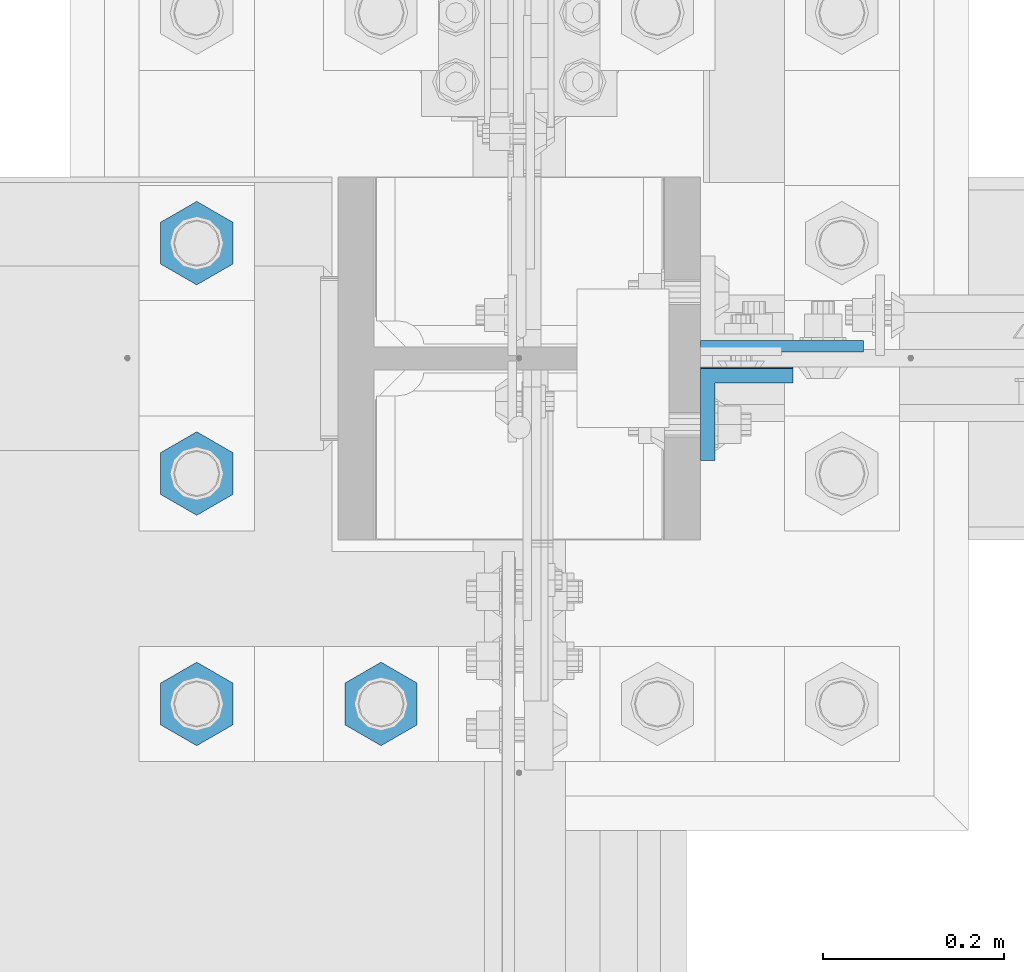
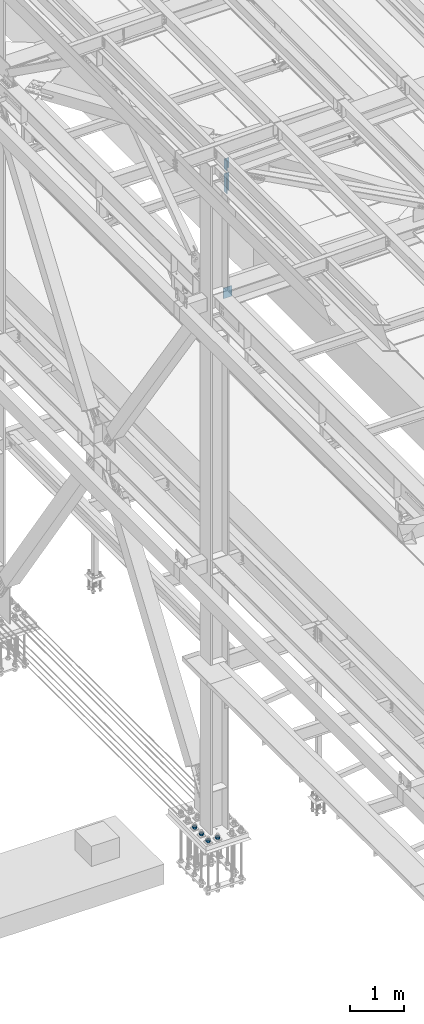
# One storey, part 1519 of 3843: 7 columns, 3 elements without a shape of their own.
"""IFC2X3 building model written with IfcOpenShell, lengths in millimetres."""

from ifc_helpers import new_model, si_unit, frame, origin_with_axes, place, context, subcontext, project, spatial, faceted_brep, material, type_object, element, aggregate, save


model = new_model("IFC2X3")

# Units and contexts
model_context = context("Model", 3, precision=1e-05, world=origin_with_axes())
body_context = subcontext(model_context, "Body", "Model", "MODEL_VIEW")
ifc_project = project(units=[si_unit("LENGTHUNIT", "METRE", prefix="MILLI"), si_unit("AREAUNIT", "SQUARE_METRE"), si_unit("VOLUMEUNIT", "CUBIC_METRE"), si_unit("MASSUNIT", "GRAM", prefix="KILO"), si_unit("TIMEUNIT", "SECOND"), si_unit("PLANEANGLEUNIT", "RADIAN"), si_unit("SOLIDANGLEUNIT", "STERADIAN"), si_unit("THERMODYNAMICTEMPERATUREUNIT", "DEGREE_CELSIUS"), si_unit("LUMINOUSINTENSITYUNIT", "LUMEN")], contexts=[model_context])

# Site, building, storey
site_placement = place(None, origin_with_axes())
site = spatial("IfcSite", under=ifc_project, at=site_placement, CompositionType="ELEMENT")
building_placement = place(site_placement, origin_with_axes())
building = spatial("IfcBuilding", under=site, at=building_placement, Name="Undefined", CompositionType="ELEMENT")
storey_placement = place(building_placement, origin_with_axes())
storey = spatial("IfcBuildingStorey", under=building, at=storey_placement, Name="Undefined", CompositionType="ELEMENT", Elevation=0.0)

# Assembly, columns
assembly_1_placement = place(storey_placement, origin_with_axes())
assembly_1 = element("IfcElementAssembly", 1, at=assembly_1_placement, inside=storey, Name="BEAM", AssemblyPlace="NOTDEFINED", PredefinedType="RIGID_FRAME")
ifc_material = material(Name="STEEL/A572-50")
column_type_1 = type_object("IfcColumnType", Name="L4X4X5/8", PredefinedType="NOTDEFINED")
column_1_placement = place(assembly_1_placement, frame((36826.8250000142, 50496.7879995346, 45113.5309641297), z_axis=(0.0, -1.0, 0.0), x_axis=(0.0, 0.0, 1.0)))
column_1 = element("IfcColumn", 2, at=column_1_placement, type_object=column_type_1, material=ifc_material, Name="ANGLE", ObjectType="L4X4X5/8", context=body_context, shape_type="Brep", body=[
    faceted_brep([(0.0, 50.8000000000029, -50.8000000000029), (0.0, 50.8000000000029, 50.8000000000029), (228.615985072276, 50.8000000000029, 50.8000000000029), (228.615985072276, 50.8000000000029, -50.8000000000029), (0.0, 34.9250000000029, 50.8000000000029), (228.615985072276, 34.9250000000029, 50.8000000000029), (0.0, 34.9250000000029, -34.9250000000029), (228.615985072276, 34.9250000000029, -34.9250000000029), (0.0, -50.8000000000029, -34.9250000000029), (228.615985072276, -50.8000000000029, -34.9250000000029), (0.0, -50.8000000000029, -50.8000000000029), (228.615985072276, -50.8000000000029, -50.8000000000029)], [[[0, 1, 2, 3]], [[1, 4, 5, 2]], [[4, 6, 7, 5]], [[6, 8, 9, 7]], [[8, 10, 11, 9]], [[10, 0, 3, 11]], [[5, 7, 9, 11, 3, 2]], [[10, 8, 6, 4, 1, 0]]]),
])
column_2_placement = place(assembly_1_placement, frame((36826.825, 50498.3750003815, 44597.892297617), z_axis=(0.0, -1.0, 0.0), x_axis=(0.0, 0.0, 1.0)))
column_2 = element("IfcColumn", 3, at=column_2_placement, type_object=column_type_1, material=ifc_material, Name="ANGLE", ObjectType="L4X4X5/8", context=body_context, shape_type="Brep", body=[
    faceted_brep([(0.0, 50.8000000000029, -50.8000000000029), (0.0, 50.8000000000029, 50.8000000000029), (406.399999999841, 50.799999998344, 50.8000000000029), (406.399999999841, 50.799999998344, -50.8000000000029), (0.0, 34.9250000000029, 50.8000000000029), (406.399999999892, 34.924999998344, 50.8000000000029), (0.0, 34.9250000000029, -34.9250000000029), (406.399999999892, 34.924999998344, -34.9250000000029), (0.0, -50.8000000000029, -34.9250000000029), (406.400000000162, -50.8000000016473, -34.9250000000029), (0.0, -50.8000000000029, -50.8000000000029), (406.400000000162, -50.8000000016473, -50.8000000000029)], [[[0, 1, 2, 3]], [[1, 4, 5, 2]], [[4, 6, 7, 5]], [[6, 8, 9, 7]], [[8, 10, 11, 9]], [[10, 0, 3, 11]], [[5, 7, 9, 11, 3, 2]], [[10, 8, 6, 4, 1, 0]]]),
])
aggregate(assembly_1, [column_1, column_2])

# Assembly, column
assembly_2_placement = place(storey_placement, origin_with_axes())
assembly_2 = element("IfcElementAssembly", 4, at=assembly_2_placement, inside=storey, Name="COLUMN", AssemblyPlace="NOTDEFINED", PredefinedType="RIGID_FRAME")
column_type_2 = type_object("IfcColumnType", PredefinedType="NOTDEFINED")
column_3_placement = place(assembly_2_placement, frame((36865.695499999, 50572.19375, 42133.8279016006), z_axis=(-1.0, 0.0, 0.0), x_axis=(0.0, 0.0, 1.0)))
column_3 = element("IfcColumn", 5, at=column_3_placement, type_object=column_type_2, material=ifc_material, Name="PLATE", context=body_context, shape_type="Brep", body=[
    faceted_brep([(0.0, 6.35000000000582, -89.6705000000002), (0.0, 6.35000000000582, 89.6705000000002), (241.299999999996, 6.35000000000582, 89.6705000000002), (241.299999999996, 6.35000000000582, -89.6705000000002), (0.0, -6.35000000000582, 89.6705000000002), (241.299999999996, -6.35000000000582, 89.6705000000002), (0.0, -6.35000000000582, -89.6705000000002), (241.299999999996, -6.35000000000582, -89.6705000000002)], [[[0, 1, 2, 3]], [[1, 4, 5, 2]], [[4, 6, 7, 5]], [[6, 0, 3, 7]], [[5, 7, 3, 2]], [[6, 4, 1, 0]]]),
])
aggregate(assembly_2, [column_3])

# Assembly, columns
assembly_3_placement = place(storey_placement, origin_with_axes())
assembly_3 = element("IfcElementAssembly", 6, at=assembly_3_placement, inside=storey, Name="TEMPLATE", AssemblyPlace="NOTDEFINED", PredefinedType="RIGID_FRAME")
column_type_3 = type_object("IfcColumnType", Name="2_HEAVY_HEX_NUT", PredefinedType="NOTDEFINED")
column_4_placement = place(assembly_3_placement, frame((36423.6, 50177.7, 30232.35), z_axis=(1.0, 0.0, 0.0), x_axis=(0.0, 0.0, -1.0)))
column_4 = element("IfcColumn", 7, at=column_4_placement, type_object=column_type_3, material=ifc_material, Name="NUT", ObjectType="2_HEAVY_HEX_NUT", context=body_context, shape_type="Brep", body=[
    faceted_brep([(0.0, -46.0369987487793, 0.0), (0.0, -23.0184993743896, -39.869213104248), (50.7999999999993, -23.0184993743896, -39.869213104248), (50.7999999999993, -46.0369987487793, 0.0), (0.0, 23.0184993743896, -39.869213104248), (50.7999999999993, 23.0184993743896, -39.869213104248), (0.0, 46.0369987487793, 0.0), (50.7999999999993, 46.0369987487793, 0.0), (0.0, 23.0184993743896, 39.869213104248), (50.7999999999993, 23.0184993743896, 39.869213104248), (0.0, -23.0184993743896, 39.869213104248), (50.7999999999993, -23.0184993743896, 39.869213104248), (0.0, 0.0, 26.1940002441406), (0.0, 11.3650617044477, 23.5999013092805), (50.7999999999993, 11.3650617044477, 23.5999013092805), (50.7999999999993, 0.0, 26.1940002441406), (0.0, 20.4791109456419, 16.3316083006721), (50.7999999999993, 20.4791109456419, 16.3316083006721), (0.0, 25.5370200498292, 5.82867859874386), (50.7999999999993, 25.5370200498292, 5.82867859874386), (0.0, 25.5370200498292, -5.82867859874386), (50.7999999999993, 25.5370200498292, -5.82867859874386), (0.0, 20.4791109456419, -16.3316083006721), (50.7999999999993, 20.4791109456419, -16.3316083006721), (0.0, 11.3650617044477, -23.5999013092805), (50.7999999999993, 11.3650617044477, -23.5999013092805), (0.0, 0.0, -26.1940002441406), (50.7999999999993, 0.0, -26.1940002441406), (0.0, -11.3650617044477, -23.5999013092805), (50.7999999999993, -11.3650617044477, -23.5999013092805), (0.0, -20.4791109456419, -16.3316083006721), (50.7999999999993, -20.4791109456419, -16.3316083006721), (0.0, -25.5370200498292, -5.82867859874386), (50.7999999999993, -25.5370200498292, -5.82867859874386), (0.0, -25.5370200498292, 5.82867859874386), (50.7999999999993, -25.5370200498292, 5.82867859874386), (0.0, -20.4791109456419, 16.3316083006721), (50.7999999999993, -20.4791109456419, 16.3316083006721), (0.0, -11.3650617044477, 23.5999013092805), (50.7999999999993, -11.3650617044477, 23.5999013092805)], [[[0, 1, 2, 3]], [[1, 4, 5, 2]], [[4, 6, 7, 5]], [[6, 8, 9, 7]], [[8, 10, 11, 9]], [[10, 0, 3, 11]], [[12, 13, 14, 15]], [[13, 16, 17, 14]], [[16, 18, 19, 17]], [[18, 20, 21, 19]], [[20, 22, 23, 21]], [[22, 24, 25, 23]], [[24, 26, 27, 25]], [[26, 28, 29, 27]], [[28, 30, 31, 29]], [[30, 32, 33, 31]], [[32, 34, 35, 33]], [[34, 36, 37, 35]], [[36, 38, 39, 37]], [[38, 12, 15, 39]], [[5, 7, 9, 11, 3, 2], [17, 19, 21, 23, 25, 27, 29, 31, 33, 35, 37, 39, 15, 14]], [[10, 8, 6, 4, 1, 0], [38, 36, 34, 32, 30, 28, 26, 24, 22, 20, 18, 16, 13, 12]]]),
])
column_5_placement = place(assembly_3_placement, frame((36220.4, 50177.7, 30232.35), z_axis=(1.0, 0.0, 0.0), x_axis=(0.0, 0.0, -1.0)))
column_5 = element("IfcColumn", 8, at=column_5_placement, type_object=column_type_3, material=ifc_material, Name="NUT", ObjectType="2_HEAVY_HEX_NUT", context=body_context, shape_type="Brep", body=[
    faceted_brep([(0.0, -46.0369987487793, 0.0), (0.0, -23.0184993743896, -39.869213104248), (50.7999999999993, -23.0184993743896, -39.869213104248), (50.7999999999993, -46.0369987487793, 0.0), (0.0, 23.0184993743896, -39.869213104248), (50.7999999999993, 23.0184993743896, -39.869213104248), (0.0, 46.0369987487793, 0.0), (50.7999999999993, 46.0369987487793, 0.0), (0.0, 23.0184993743896, 39.869213104248), (50.7999999999993, 23.0184993743896, 39.869213104248), (0.0, -23.0184993743896, 39.869213104248), (50.7999999999993, -23.0184993743896, 39.869213104248), (0.0, 0.0, 26.1940002441406), (0.0, 11.3650617044477, 23.5999013092805), (50.7999999999993, 11.3650617044477, 23.5999013092805), (50.7999999999993, 0.0, 26.1940002441406), (0.0, 20.4791109456419, 16.3316083006721), (50.7999999999993, 20.4791109456419, 16.3316083006721), (0.0, 25.5370200498292, 5.82867859874386), (50.7999999999993, 25.5370200498292, 5.82867859874386), (0.0, 25.5370200498292, -5.82867859874386), (50.7999999999993, 25.5370200498292, -5.82867859874386), (0.0, 20.4791109456419, -16.3316083006721), (50.7999999999993, 20.4791109456419, -16.3316083006721), (0.0, 11.3650617044477, -23.5999013092805), (50.7999999999993, 11.3650617044477, -23.5999013092805), (0.0, 0.0, -26.1940002441406), (50.7999999999993, 0.0, -26.1940002441406), (0.0, -11.3650617044477, -23.5999013092805), (50.7999999999993, -11.3650617044477, -23.5999013092805), (0.0, -20.4791109456419, -16.3316083006721), (50.7999999999993, -20.4791109456419, -16.3316083006721), (0.0, -25.5370200498292, -5.82867859874386), (50.7999999999993, -25.5370200498292, -5.82867859874386), (0.0, -25.5370200498292, 5.82867859874386), (50.7999999999993, -25.5370200498292, 5.82867859874386), (0.0, -20.4791109456419, 16.3316083006721), (50.7999999999993, -20.4791109456419, 16.3316083006721), (0.0, -11.3650617044477, 23.5999013092805), (50.7999999999993, -11.3650617044477, 23.5999013092805)], [[[0, 1, 2, 3]], [[1, 4, 5, 2]], [[4, 6, 7, 5]], [[6, 8, 9, 7]], [[8, 10, 11, 9]], [[10, 0, 3, 11]], [[12, 13, 14, 15]], [[13, 16, 17, 14]], [[16, 18, 19, 17]], [[18, 20, 21, 19]], [[20, 22, 23, 21]], [[22, 24, 25, 23]], [[24, 26, 27, 25]], [[26, 28, 29, 27]], [[28, 30, 31, 29]], [[30, 32, 33, 31]], [[32, 34, 35, 33]], [[34, 36, 37, 35]], [[36, 38, 39, 37]], [[38, 12, 15, 39]], [[5, 7, 9, 11, 3, 2], [17, 19, 21, 23, 25, 27, 29, 31, 33, 35, 37, 39, 15, 14]], [[10, 8, 6, 4, 1, 0], [38, 36, 34, 32, 30, 28, 26, 24, 22, 20, 18, 16, 13, 12]]]),
])
column_6_placement = place(assembly_3_placement, frame((36220.4, 50431.7, 30232.35), z_axis=(1.0, 0.0, 0.0), x_axis=(0.0, 0.0, -1.0)))
column_6 = element("IfcColumn", 9, at=column_6_placement, type_object=column_type_3, material=ifc_material, Name="NUT", ObjectType="2_HEAVY_HEX_NUT", context=body_context, shape_type="Brep", body=[
    faceted_brep([(0.0, -46.0369987487793, 0.0), (0.0, -23.0184993743896, -39.869213104248), (50.7999999999993, -23.0184993743896, -39.869213104248), (50.7999999999993, -46.0369987487793, 0.0), (0.0, 23.0184993743896, -39.869213104248), (50.7999999999993, 23.0184993743896, -39.869213104248), (0.0, 46.0369987487793, 0.0), (50.7999999999993, 46.0369987487793, 0.0), (0.0, 23.0184993743896, 39.869213104248), (50.7999999999993, 23.0184993743896, 39.869213104248), (0.0, -23.0184993743896, 39.869213104248), (50.7999999999993, -23.0184993743896, 39.869213104248), (0.0, 0.0, 26.1940002441406), (0.0, 11.3650617044477, 23.5999013092805), (50.7999999999993, 11.3650617044477, 23.5999013092805), (50.7999999999993, 0.0, 26.1940002441406), (0.0, 20.4791109456419, 16.3316083006721), (50.7999999999993, 20.4791109456419, 16.3316083006721), (0.0, 25.5370200498292, 5.82867859874386), (50.7999999999993, 25.5370200498292, 5.82867859874386), (0.0, 25.5370200498292, -5.82867859874386), (50.7999999999993, 25.5370200498292, -5.82867859874386), (0.0, 20.4791109456419, -16.3316083006721), (50.7999999999993, 20.4791109456419, -16.3316083006721), (0.0, 11.3650617044477, -23.5999013092805), (50.7999999999993, 11.3650617044477, -23.5999013092805), (0.0, 0.0, -26.1940002441406), (50.7999999999993, 0.0, -26.1940002441406), (0.0, -11.3650617044477, -23.5999013092805), (50.7999999999993, -11.3650617044477, -23.5999013092805), (0.0, -20.4791109456419, -16.3316083006721), (50.7999999999993, -20.4791109456419, -16.3316083006721), (0.0, -25.5370200498292, -5.82867859874386), (50.7999999999993, -25.5370200498292, -5.82867859874386), (0.0, -25.5370200498292, 5.82867859874386), (50.7999999999993, -25.5370200498292, 5.82867859874386), (0.0, -20.4791109456419, 16.3316083006721), (50.7999999999993, -20.4791109456419, 16.3316083006721), (0.0, -11.3650617044477, 23.5999013092805), (50.7999999999993, -11.3650617044477, 23.5999013092805)], [[[0, 1, 2, 3]], [[1, 4, 5, 2]], [[4, 6, 7, 5]], [[6, 8, 9, 7]], [[8, 10, 11, 9]], [[10, 0, 3, 11]], [[12, 13, 14, 15]], [[13, 16, 17, 14]], [[16, 18, 19, 17]], [[18, 20, 21, 19]], [[20, 22, 23, 21]], [[22, 24, 25, 23]], [[24, 26, 27, 25]], [[26, 28, 29, 27]], [[28, 30, 31, 29]], [[30, 32, 33, 31]], [[32, 34, 35, 33]], [[34, 36, 37, 35]], [[36, 38, 39, 37]], [[38, 12, 15, 39]], [[5, 7, 9, 11, 3, 2], [17, 19, 21, 23, 25, 27, 29, 31, 33, 35, 37, 39, 15, 14]], [[10, 8, 6, 4, 1, 0], [38, 36, 34, 32, 30, 28, 26, 24, 22, 20, 18, 16, 13, 12]]]),
])
column_7_placement = place(assembly_3_placement, frame((36220.4, 50685.7, 30232.35), z_axis=(1.0, 0.0, 0.0), x_axis=(0.0, 0.0, -1.0)))
column_7 = element("IfcColumn", 10, at=column_7_placement, type_object=column_type_3, material=ifc_material, Name="NUT", ObjectType="2_HEAVY_HEX_NUT", context=body_context, shape_type="Brep", body=[
    faceted_brep([(0.0, -46.0369987487793, 0.0), (0.0, -23.0184993743896, -39.869213104248), (50.7999999999993, -23.0184993743896, -39.869213104248), (50.7999999999993, -46.0369987487793, 0.0), (0.0, 23.0184993743896, -39.869213104248), (50.7999999999993, 23.0184993743896, -39.869213104248), (0.0, 46.0369987487793, 0.0), (50.7999999999993, 46.0369987487793, 0.0), (0.0, 23.0184993743896, 39.869213104248), (50.7999999999993, 23.0184993743896, 39.869213104248), (0.0, -23.0184993743896, 39.869213104248), (50.7999999999993, -23.0184993743896, 39.869213104248), (0.0, 0.0, 26.1940002441406), (0.0, 11.3650617044477, 23.5999013092805), (50.7999999999993, 11.3650617044477, 23.5999013092805), (50.7999999999993, 0.0, 26.1940002441406), (0.0, 20.4791109456419, 16.3316083006721), (50.7999999999993, 20.4791109456419, 16.3316083006721), (0.0, 25.5370200498292, 5.82867859874386), (50.7999999999993, 25.5370200498292, 5.82867859874386), (0.0, 25.5370200498292, -5.82867859874386), (50.7999999999993, 25.5370200498292, -5.82867859874386), (0.0, 20.4791109456419, -16.3316083006721), (50.7999999999993, 20.4791109456419, -16.3316083006721), (0.0, 11.3650617044477, -23.5999013092805), (50.7999999999993, 11.3650617044477, -23.5999013092805), (0.0, 0.0, -26.1940002441406), (50.7999999999993, 0.0, -26.1940002441406), (0.0, -11.3650617044477, -23.5999013092805), (50.7999999999993, -11.3650617044477, -23.5999013092805), (0.0, -20.4791109456419, -16.3316083006721), (50.7999999999993, -20.4791109456419, -16.3316083006721), (0.0, -25.5370200498292, -5.82867859874386), (50.7999999999993, -25.5370200498292, -5.82867859874386), (0.0, -25.5370200498292, 5.82867859874386), (50.7999999999993, -25.5370200498292, 5.82867859874386), (0.0, -20.4791109456419, 16.3316083006721), (50.7999999999993, -20.4791109456419, 16.3316083006721), (0.0, -11.3650617044477, 23.5999013092805), (50.7999999999993, -11.3650617044477, 23.5999013092805)], [[[0, 1, 2, 3]], [[1, 4, 5, 2]], [[4, 6, 7, 5]], [[6, 8, 9, 7]], [[8, 10, 11, 9]], [[10, 0, 3, 11]], [[12, 13, 14, 15]], [[13, 16, 17, 14]], [[16, 18, 19, 17]], [[18, 20, 21, 19]], [[20, 22, 23, 21]], [[22, 24, 25, 23]], [[24, 26, 27, 25]], [[26, 28, 29, 27]], [[28, 30, 31, 29]], [[30, 32, 33, 31]], [[32, 34, 35, 33]], [[34, 36, 37, 35]], [[36, 38, 39, 37]], [[38, 12, 15, 39]], [[5, 7, 9, 11, 3, 2], [17, 19, 21, 23, 25, 27, 29, 31, 33, 35, 37, 39, 15, 14]], [[10, 8, 6, 4, 1, 0], [38, 36, 34, 32, 30, 28, 26, 24, 22, 20, 18, 16, 13, 12]]]),
])
aggregate(assembly_3, [column_4, column_5, column_6, column_7])

save(model, "model.ifc")
